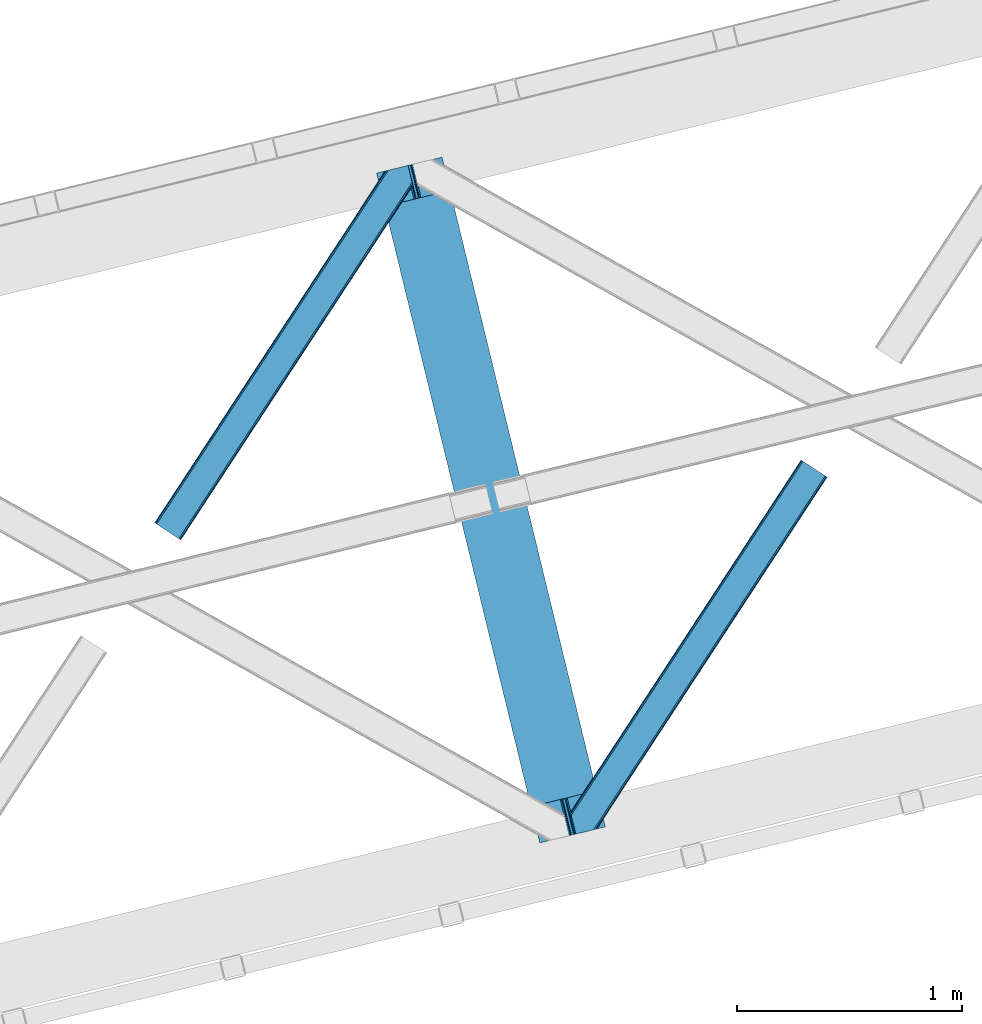
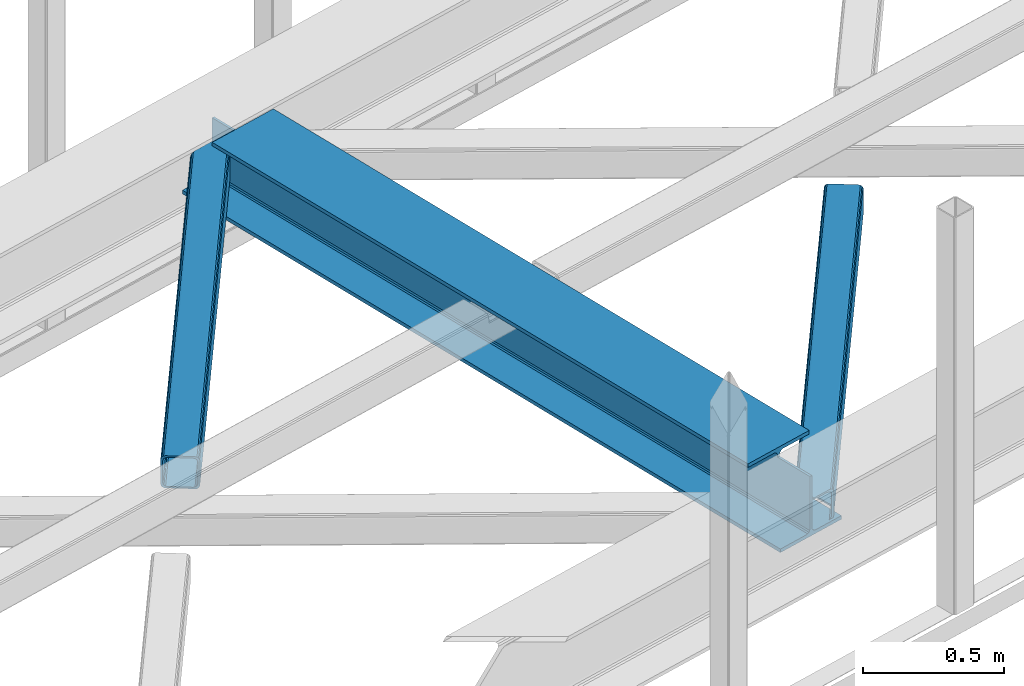
# One storey, part 27 of 67: 2 members, 1 beam.
"""IFC4 building model written with IfcOpenShell, lengths in millimetres."""

from ifc_helpers import new_model, entity, si_unit, converted_unit, derived_unit, direction, frame, origin, place, context, subcontext, project, spatial, triangles, polygons, material, type_object, element, save


model = new_model("IFC4")

# Units and contexts
model_context = context("Model", 3, precision=0.01, world=origin(), true_north=direction((6.12303176911189e-17, 1.0)))
plan_context = context("Plan", 3, precision=0.01, world=origin(), true_north=direction((6.12303176911189e-17, 1.0)))
body_context = subcontext(model_context, "Body", "Model", "MODEL_VIEW")
ifc_project = project(units=[si_unit("LENGTHUNIT", "METRE", prefix="MILLI"), si_unit("AREAUNIT", "SQUARE_METRE"), si_unit("VOLUMEUNIT", "CUBIC_METRE"), converted_unit("PLANEANGLEUNIT", "DEGREE", entity("IfcRatioMeasure", 0.0174532925199433), si_unit("PLANEANGLEUNIT", "RADIAN"), dimensions=[0, 0, 0, 0, 0, 0, 0]), si_unit("MASSUNIT", "GRAM", prefix="KILO"), derived_unit("MASSDENSITYUNIT", [(si_unit("MASSUNIT", "GRAM", prefix="KILO"), 1), (si_unit("LENGTHUNIT", "METRE"), -3)]), derived_unit("MOMENTOFINERTIAUNIT", [(si_unit("LENGTHUNIT", "METRE"), 4)]), si_unit("TIMEUNIT", "SECOND"), si_unit("FREQUENCYUNIT", "HERTZ"), si_unit("THERMODYNAMICTEMPERATUREUNIT", "DEGREE_CELSIUS"), derived_unit("THERMALTRANSMITTANCEUNIT", [(si_unit("MASSUNIT", "GRAM", prefix="KILO"), 1), (si_unit("THERMODYNAMICTEMPERATUREUNIT", "KELVIN"), -1), (si_unit("TIMEUNIT", "SECOND"), -3)]), derived_unit("VOLUMETRICFLOWRATEUNIT", [(si_unit("LENGTHUNIT", "METRE"), 3), (si_unit("TIMEUNIT", "SECOND"), -1)]), derived_unit("MASSFLOWRATEUNIT", [(si_unit("MASSUNIT", "GRAM", prefix="KILO"), 1), (si_unit("TIMEUNIT", "SECOND"), -1)]), derived_unit("ROTATIONALFREQUENCYUNIT", [(si_unit("TIMEUNIT", "SECOND"), -1)]), si_unit("ELECTRICCURRENTUNIT", "AMPERE"), si_unit("ELECTRICVOLTAGEUNIT", "VOLT"), si_unit("POWERUNIT", "WATT"), si_unit("FORCEUNIT", "NEWTON", prefix="KILO"), si_unit("ILLUMINANCEUNIT", "LUX"), si_unit("LUMINOUSFLUXUNIT", "LUMEN"), si_unit("LUMINOUSINTENSITYUNIT", "CANDELA"), derived_unit("USERDEFINED", [(si_unit("MASSUNIT", "GRAM", prefix="KILO"), -1), (si_unit("LENGTHUNIT", "METRE"), -2), (si_unit("TIMEUNIT", "SECOND"), 3), (si_unit("LUMINOUSFLUXUNIT", "LUMEN"), 1)]), derived_unit("LINEARVELOCITYUNIT", [(si_unit("LENGTHUNIT", "METRE"), 1), (si_unit("TIMEUNIT", "SECOND"), -1)]), si_unit("PRESSUREUNIT", "PASCAL"), derived_unit("USERDEFINED", [(si_unit("LENGTHUNIT", "METRE"), -2), (si_unit("MASSUNIT", "GRAM", prefix="KILO"), 1), (si_unit("TIMEUNIT", "SECOND"), -2)]), derived_unit("LINEARFORCEUNIT", [(si_unit("MASSUNIT", "GRAM", prefix="KILO"), 1), (si_unit("LENGTHUNIT", "METRE"), 1), (si_unit("TIMEUNIT", "SECOND"), -2), (si_unit("LENGTHUNIT", "METRE"), -1)]), derived_unit("PLANARFORCEUNIT", [(si_unit("MASSUNIT", "GRAM", prefix="KILO"), 1), (si_unit("LENGTHUNIT", "METRE"), 1), (si_unit("TIMEUNIT", "SECOND"), -2), (si_unit("LENGTHUNIT", "METRE"), -2)])], contexts=[model_context, plan_context])

# Site, building, storey
site_placement = place(None, origin())
site = spatial("IfcSite", under=ifc_project, at=site_placement, CompositionType="ELEMENT")
building_placement = place(site_placement, origin())
building = spatial("IfcBuilding", under=site, at=building_placement, CompositionType="ELEMENT")
storey_placement = place(building_placement, frame((0.0, 0.0, 19800.0)))
storey = spatial("IfcBuildingStorey", under=building, at=storey_placement, CompositionType="ELEMENT", Elevation=19800.0)

# Beam
ifc_material = material(Name="Metal painted (White)")
beam_type = type_object("IfcBeamType", PredefinedType="BEAM")
beam_placement = place(storey_placement, frame((-46287.0610062402, 6511.96838491939, 3807.02022389142)))
element("IfcBeam", 1, at=beam_placement, inside=storey, type_object=beam_type, material=ifc_material, ObjectType="Steel Beam", PredefinedType="BEAM", context=body_context, shape_type="Tessellation", body=[
    polygons([(1018.16648378329, 71.0478278971, 15.5000000000008), (1018.16648378329, 71.047827897101, 0.0), (291.465617442446, 3052.25531830421, 0.0), (291.465617442446, 3052.25531830421, 15.5000000000008), (894.779372399329, 40.970914087328, 15.5000000000008), (168.078506058474, 3022.17840449444, 15.5000000000008), (888.087028625375, 39.3395844888232, 16.8701684147984), (161.386162284528, 3020.54707489594, 16.8701684147984), (882.413533524759, 37.9566100336508, 20.7720779386434), (155.712667183904, 3019.16410044076, 20.7720779386434), (878.622625296184, 37.0325360459173, 26.6116982174294), (151.921758955329, 3018.24002645303, 26.6116982174294), (877.291435352779, 36.7080444135018, 33.500000000001), (150.590569011932, 3017.91553482061, 33.500000000001), (140.875048430522, 3015.54727389071, 33.500000000001), (140.875048430522, 3015.54727389071, 259.000000000002), (150.590569011932, 3017.91553482061, 259.000000000002), (8.66293703438714e-12, 2981.20749040711, 0.0), (8.66293703438714e-12, 2981.20749040711, 15.4999999999965), (123.387111383972, 3011.28440421689, 15.5000000000008), (130.079455157935, 3012.91573381539, 16.8701684147984), (135.752950258542, 3014.29870827056, 20.7720779386434), (139.543858487126, 3015.2227822583, 26.6116982174294), (877.291435352788, 36.7080444135029, 259.000000000002), (867.575914771378, 34.3397834835992, 259.000000000002), (867.575914771378, 34.3397834835992, 33.500000000001), (866.244724827981, 34.0152918511848, 26.6116982174294), (862.453816599397, 33.0912178634502, 20.7720779386434), (856.78032149879, 31.7082434082767, 16.8701684147984), (850.087977724828, 30.0769138097719, 15.5000000000008), (726.700866340864, 1.08286712929839e-12, 15.4999999999965), (726.700866340864, 1.08286712929839e-12, 0.0), (838.124523615921, 197.385937999178, 259.069791973884), (186.46972209998, 2870.72539801218, 259.000000000002), (186.69311520182, 2869.80895360721, 259.617303331124), (186.705504045446, 2869.75812937344, 266.500003008253), (837.979344808156, 197.981416001703, 266.500002998871), (837.979694928899, 197.979979696969, 260.000004007589), (828.499586345885, 194.64586594443, 259.006343171919), (828.27621632612, 195.562317481911, 259.617303331124), (828.263827482486, 195.613141715684, 266.500003008253), (176.989986719793, 2867.38985508742, 266.500002998871), (176.98963659904, 2867.39129139215, 260.000004007589), (176.844830940705, 2867.98534020594, 259.07612046749), (176.754201518561, 2868.35713708228, 259.000000000002), (839.310832678074, 198.304685446389, 273.388305639783), (843.10110926677, 199.231350618302, 279.227924098781), (848.774180214309, 200.616065081978, 283.129832400619), (855.466371895434, 202.248018612791, 284.500000377228), (978.853400583278, 232.325271667903, 284.500000138971), (978.851730776626, 232.332121736634, 299.999995328161), (687.386308679356, 161.283492472592, 299.999995890962), (687.387978486008, 161.276642403861, 284.500000701776), (810.775007173852, 191.353895458971, 284.500000463519), (817.467494069999, 192.984637925551, 283.129832461069), (823.141405718751, 194.365903570076, 279.227924137322), (826.932940505751, 195.287407219373, 273.388305663684), (175.658498849865, 2867.06658564273, 273.388305639783), (171.868222261161, 2866.13992047082, 279.227924098781), (166.195151313631, 2864.75520600714, 283.129832400619), (159.502959632506, 2863.12325247633, 284.500000377228), (36.1159309446533, 2833.04599942122, 284.500000138971), (36.1176007513137, 2833.03914935249, 299.999995328161), (327.583022848584, 2904.08777861653, 299.999995890962), (327.581353041932, 2904.09462868526, 284.500000701776), (204.19432435408, 2874.01737563015, 284.500000463519), (197.50183745795, 2872.38663316357, 283.129832461069), (191.827925809181, 2871.00536751905, 279.227924137322), (188.036391022189, 2870.08386386975, 273.388305663684)], [[[1, 2, 3, 4]], [[5, 1, 4, 6]], [[7, 5, 6, 8]], [[9, 7, 8, 10]], [[11, 9, 10, 12]], [[13, 11, 12, 14]], [[15, 16, 17, 14, 12, 10, 8, 6, 4, 3, 18, 19, 20, 21, 22, 23]], [[13, 24, 25, 26, 27, 28, 29, 30, 31, 32, 2, 1, 5, 7, 9, 11]], [[2, 32, 18, 3]], [[32, 31, 19, 18]], [[31, 30, 20, 19]], [[27, 26, 15, 23]], [[28, 27, 23, 22]], [[29, 28, 22, 21]], [[30, 29, 21, 20]], [[33, 24, 13, 14, 17, 34, 35, 36, 37, 38]], [[25, 39, 40, 41, 42, 43, 44, 16, 15, 26]], [[39, 25, 24, 33]], [[45, 34, 17, 16]], [[41, 40, 38, 37, 46, 47, 48, 49, 50, 51, 52, 53, 54, 55, 56, 57]], [[42, 58, 59, 60, 61, 62, 63, 64, 65, 66, 67, 68, 69, 36, 35, 43]], [[46, 37, 36, 69]], [[47, 46, 69, 68]], [[48, 47, 68, 67]], [[49, 48, 67, 66]], [[50, 49, 66, 65]], [[51, 50, 65, 64]], [[52, 51, 64, 63]], [[53, 52, 63, 62]], [[54, 53, 62, 61]], [[55, 54, 61, 60]], [[56, 55, 60, 59]], [[57, 56, 59, 58]], [[41, 57, 58, 42]]], closed=False),
])

# Members
member_type_1 = type_object("IfcMemberType", PredefinedType="BRACE")
member_1_placement = place(storey_placement, frame((-47275.2632080078, 7859.97314300537, 3823.99987792968)))
element("IfcMember", 2, at=member_1_placement, inside=storey, type_object=member_type_1, ObjectType="Steel Horizontal Brace", PredefinedType="BRACE", context=body_context, shape_type="Tessellation", body=[
    triangles([(994.771838378903, 1564.02662658691, 0.0), (1028.82092285156, 1424.34736175537, 0.0), (14.6409667968692, 67.104043579101, 0.0), (102.482116699219, 9.58604278564417, 0.0), (1.11156005859084, 75.9604797363281, 10.8039916992202), (0.0, 76.6900863647461, 17.5012573242202), (1025.02580566406, 1642.17883300781, 17.5012573242202), (4.28811035156104, 73.8821182250977, 5.12526855468968), (990.474426269531, 1585.87703704834, 9.49942016601563), (990.041894531249, 1584.44747314453, 8.74132690429906), (989.907019042963, 1583.99226837158, 8.49948120117188), (990.758129882808, 1580.48841247559, 5.12526855468968), (1027.30473632812, 1642.73519439697, 10.8691040039084), (1027.77912597656, 1642.8503036499, 9.49942016601563), (992.599877929686, 1572.93538513184, 1.33247680664135), (9.03665771483793, 70.7724243164057, 1.33247680664135), (1025.02580566406, 1642.17883300781, 122.499499511719), (0.0, 76.6900863647461, 122.499499511719), (1026.9187133789, 1642.64101409912, 129.196765136719), (1.11156005859084, 75.9604797363281, 129.196765136719), (1032.31373291015, 1643.95605010986, 134.87548828125), (4.28811035156104, 73.8821182250977, 134.87548828125), (1040.39230957031, 1645.92395324707, 138.668280029298), (9.03665771483793, 70.7724243164057, 138.668280029298), (1049.91730957031, 1648.24590454102, 140.00075683594), (14.6409667968692, 67.104043579101, 140.00075683594), (994.869506835938, 1567.85139312744, 9.49942016601563), (994.757885742183, 1567.00667724609, 9.2947814941399), (994.646264648436, 1566.15091552734, 9.08781738281323), (994.539294433591, 1565.306199646, 8.8831787109375), (994.743933105463, 1564.14464263916, 8.49948120117188), (1047.05236816406, 1647.54827270508, 9.49942016601563), (14.892114257811, 66.9377746582031, 8.3320495605476), (20.4964233398423, 63.2693939208984, 6.99957275390625), (997.041467285155, 1554.71498565674, 6.99957275390625), (10.1435668945269, 70.0474685668942, 12.1248413085959), (1042.27126464844, 1646.3826461792, 12.1248413085959), (1036.87624511719, 1645.06761016846, 17.8035644531265), (1034.98333740234, 1644.60601043701, 24.5008300781265), (6.96701660155668, 72.1258300781246, 17.8035644531265), (5.85545654296584, 72.8554367065426, 24.5008300781265), (1026.55129394531, 1433.65958404541, 6.99957275390625), (96.6266601562456, 13.4206924438477, 6.99957275390625), (1028.71395263672, 1424.77640533447, 8.41343994140698), (1032.83463134765, 1407.88615722656, 5.12526855468968), (1033.6857421875, 1404.38230133057, 8.49948120117188), (1030.99288330078, 1415.43918457031, 1.33247680664135), (1034.98333740234, 1644.60601043701, 115.499926757813), (5.85545654296584, 72.8554367065426, 115.499926757813), (1050.34519042968, 1648.35113067627, 131.668707275392), (1059.87019042968, 1650.67308197021, 133.001184082033), (20.4964233398423, 63.2693939208984, 133.001184082033), (14.892114257811, 66.9377746582031, 131.668707275392), (1042.27126464844, 1646.3826461792, 127.873590087893), (10.1435668945269, 70.0474685668942, 127.873590087893), (1036.87624511719, 1645.06761016846, 122.197192382813), (6.96701660155668, 72.1258300781246, 122.197192382813), (1128.10788574218, 1667.30578765869, 140.00075683594), (1128.10788574218, 1667.30578765869, 133.001184082033), (1144.32550048828, 1600.75810546875, 140.00075683594), (102.482116699219, 9.58604278564417, 140.00075683594), (1142.05587158203, 1610.06974639893, 133.001184082033), (96.6266601562456, 13.4206924438477, 133.001184082033), (1146.4974609375, 1591.84934692383, 138.668280029298), (108.08642578125, 5.91766204833948, 138.668280029298), (1148.33920898437, 1584.29631958008, 134.87548828125), (112.834973144527, 2.80738677978479, 134.87548828125), (1149.57169189453, 1579.2501159668, 129.196765136719), (116.011523437497, 0.729606628417969, 129.196765136719), (1150.00422363281, 1577.47813110352, 122.499499511719), (117.123083496088, 0.0, 122.499499511719), (1150.00422363281, 1577.47813110352, 17.5012573242202), (117.123083496088, 0.0, 17.5012573242202), (106.979516601561, 6.64203643798828, 127.873590087893), (110.151416015622, 4.56425628662055, 122.197192382813), (111.267626953122, 3.83464965820258, 115.499926757813), (102.230969238277, 9.75231170654297, 131.668707275392), (116.011523437497, 0.729606628417969, 10.8039916992202), (106.979516601561, 6.64203643798828, 12.1248413085959), (112.834973144527, 2.80738677978479, 5.12526855468968), (111.267626953122, 3.83464965820258, 24.5008300781265), (110.151416015622, 4.56425628662055, 17.8035644531265), (108.08642578125, 5.91766204833948, 1.33247680664135), (102.230969238277, 9.75231170654297, 8.3320495605476), (1147.30206298828, 1588.56233825684, 122.197192382813), (1147.73459472656, 1586.78977203369, 115.499926757813), (1146.06958007813, 1593.60854187012, 127.873590087893), (1144.22783203125, 1601.160987854, 131.668707275392), (1147.73459472656, 1586.78977203369, 24.5008300781265), (1147.21369628906, 1588.9239440918, 17.8686767578147), (1149.994921875, 1577.51591949463, 16.5013183593765), (1147.10672607421, 1589.36519622803, 16.5013183593765), (1145.27427978515, 1573.10804901123, 10.8714294433594), (1034.61591796875, 1404.78809051514, 9.49942016601563), (1144.12551269531, 1572.03427734375, 9.49942016601563), (1142.79071044922, 1588.5978012085, 12.1248413085959), (1030.22548828125, 1422.8143157959, 9.49942016601563), (1029.19764404296, 1423.6724029541, 8.80643920898365), (1139.7304321289, 1590.05992126465, 9.49942016601563)], [[1, 2, 3], [4, 3, 2], [5, 6, 7], [8, 9, 10], [11, 12, 8], [5, 13, 9], [9, 8, 5], [13, 14, 9], [15, 1, 16], [3, 16, 1], [12, 15, 8], [16, 8, 15], [7, 13, 5], [17, 7, 18], [6, 18, 7], [19, 17, 20], [18, 20, 17], [21, 19, 22], [20, 22, 19], [23, 21, 24], [22, 24, 21], [25, 23, 26], [24, 26, 23], [27, 28, 9], [28, 29, 10], [29, 30, 10], [30, 31, 11], [14, 32, 27], [27, 9, 14], [33, 34, 35], [36, 33, 31], [31, 30, 36], [28, 36, 29], [28, 27, 36], [36, 30, 29], [32, 37, 27], [36, 27, 37], [35, 31, 33], [38, 39, 40], [41, 40, 39], [37, 38, 36], [40, 36, 38], [42, 35, 34], [34, 43, 42], [1, 35, 42], [31, 12, 11], [1, 31, 35], [31, 15, 12], [31, 1, 15], [2, 1, 42], [44, 2, 42], [45, 44, 46], [44, 47, 2], [44, 45, 47], [39, 48, 49], [49, 41, 39], [50, 51, 52], [52, 53, 50], [54, 50, 53], [53, 55, 54], [56, 54, 55], [55, 57, 56], [48, 56, 57], [57, 49, 48], [56, 17, 19], [50, 23, 25], [58, 51, 25], [51, 58, 59], [51, 50, 25], [54, 23, 50], [54, 56, 21], [21, 23, 54], [19, 21, 56], [39, 7, 17], [37, 14, 38], [56, 48, 17], [37, 32, 14], [39, 38, 7], [48, 39, 17], [13, 7, 38], [38, 14, 13], [60, 25, 61], [25, 60, 58], [26, 61, 25], [51, 62, 63], [51, 59, 62], [63, 52, 51], [64, 60, 61], [61, 65, 64], [66, 64, 65], [65, 67, 66], [68, 66, 67], [67, 69, 68], [70, 68, 69], [69, 71, 70], [72, 70, 71], [71, 73, 72], [69, 74, 75], [76, 73, 71], [69, 75, 71], [69, 67, 74], [75, 76, 71], [74, 67, 65], [63, 61, 26], [61, 77, 65], [77, 61, 63], [77, 74, 65], [78, 79, 80], [81, 73, 76], [73, 82, 78], [82, 73, 81], [78, 82, 79], [4, 43, 3], [83, 80, 79], [79, 84, 83], [84, 43, 4], [4, 83, 84], [55, 24, 22], [26, 52, 63], [26, 53, 52], [53, 26, 24], [55, 53, 24], [49, 18, 6], [20, 57, 55], [22, 20, 55], [57, 20, 18], [49, 57, 18], [16, 36, 8], [3, 43, 34], [34, 33, 3], [33, 36, 16], [16, 3, 33], [5, 8, 36], [6, 41, 49], [40, 6, 5], [6, 40, 41], [40, 5, 36], [85, 86, 75], [76, 75, 86], [87, 85, 74], [75, 74, 85], [88, 87, 77], [74, 77, 87], [62, 88, 63], [77, 63, 88], [86, 89, 76], [81, 76, 89], [90, 91, 92], [70, 72, 89], [72, 90, 89], [89, 86, 70], [72, 91, 90], [85, 70, 86], [68, 70, 85], [66, 85, 87], [85, 66, 68], [87, 64, 66], [88, 64, 87], [88, 62, 60], [88, 60, 64], [62, 58, 60], [62, 59, 58], [73, 78, 93], [93, 72, 73], [94, 93, 78], [94, 95, 93], [80, 45, 46], [46, 78, 80], [46, 94, 78], [47, 45, 83], [80, 83, 45], [2, 47, 4], [83, 4, 47], [93, 91, 72], [82, 81, 89], [82, 92, 96], [82, 90, 92], [84, 97, 98], [79, 96, 97], [97, 84, 79], [96, 99, 97], [43, 84, 44], [44, 42, 43], [96, 79, 82], [89, 90, 82], [96, 91, 93], [96, 92, 91], [96, 95, 99], [93, 95, 96], [99, 95, 97], [94, 97, 95]]),
])
member_type_2 = type_object("IfcMemberType", PredefinedType="BRACE")
member_2_placement = place(storey_placement, frame((-45423.9436523438, 6551.04489898682, 3823.99987792968)))
element("IfcMember", 3, at=member_2_placement, inside=storey, type_object=member_type_2, ObjectType="Steel Horizontal Brace", PredefinedType="BRACE", context=body_context, shape_type="Tessellation", body=[
    triangles([(109.770043945318, 259.949830627442, 7.52047119140843), (115.030187988283, 238.365682983399, 7.77626953125218), (114.216284179689, 239.946981811524, 8.3320495605476), (108.811962890628, 259.662057495118, 8.52041015625218), (113.634924316408, 239.859196472168, 8.52041015625218), (112.20710449219, 237.677352905273, 8.52041015625218), (91.0363037109419, 232.516621398926, 8.52041015625218), (109.537500000006, 237.026229858398, 9.49942016601563), (90.2642578125015, 232.328260803223, 9.49942016601563), (5.02294921875, 77.405158996582, 9.49942016601563), (0.62786865234375, 95.4308029174808, 9.49942016601563), (1046.62448730469, 1651.75324859619, 6.99957275390625), (1041.02017822266, 1655.4216293335, 8.3320495605476), (116.699853515631, 231.514938354492, 6.99957275390625), (1036.27163085938, 1658.53190460205, 12.1248413085959), (3.92999267578125, 81.8752349853521, 12.1248413085959), (1033.09973144531, 1660.61026611328, 17.8035644531265), (2.70216064453416, 86.9220199584961, 17.8035644531265), (1031.98352050781, 1661.3398727417, 24.5008300781265), (2.26962890625146, 88.6940048217775, 24.5008300781265), (1122.7547241211, 1601.90454711914, 6.99957275390625), (146.209680175787, 110.459536743164, 6.99957275390625), (1031.98352050781, 1661.3398727417, 115.499926757813), (2.26962890625146, 88.6940048217775, 115.499926757813), (1033.09973144531, 1660.61026611328, 122.197192382813), (2.70216064453416, 86.9220199584961, 122.197192382813), (1036.27163085938, 1658.53190460205, 127.873590087893), (3.92999267578125, 81.8752349853521, 127.873590087893), (1041.02017822266, 1655.4216293335, 131.668707275392), (5.77174072265916, 74.322789001465, 131.668707275392), (1046.62448730469, 1651.75324859619, 133.001184082033), (7.94370117187646, 65.4140304565435, 133.001184082033), (1027.24427490235, 1664.44433441162, 10.8039916992202), (0.520898437505821, 95.8714736938482, 10.8691040039084), (0.0, 98.0056457519531, 17.5012573242202), (1035.16472167969, 1659.2562789917, 1.33247680664135), (112.258264160162, 249.73533782959, 1.33247680664135), (110.546740722661, 256.772117614746, 5.59500732422021), (109.077062988283, 259.839372253418, 8.32042236328198), (1030.41617431641, 1662.36655426025, 5.12526855468968), (1040.76903076172, 1655.58789825439, 0.0), (114.430224609379, 240.826579284668, 0.0), (1026.12806396485, 1665.1745223999, 17.5012573242202), (1128.61018066407, 1598.06989746094, 0.0), (148.479309082031, 101.147314453126, 0.0), (150.651269531256, 92.2385559082031, 1.33247680664135), (148.507214355472, 101.029298400879, 8.49948120117188), (152.493017578126, 84.686109924317, 5.12526855468968), (153.348779296881, 81.1822540283201, 8.49948120117188), (1026.12806396485, 1665.1745223999, 122.499499511719), (0.0, 98.0056457519531, 122.499499511719), (1040.76903076172, 1655.58789825439, 140.00075683594), (1035.16472167969, 1659.2562789917, 138.668280029298), (3.50211181640771, 83.6350112915043, 138.668280029298), (5.674072265625, 74.7256713867191, 140.00075683594), (1030.41617431641, 1662.36655426025, 134.87548828125), (1.66036376953707, 91.1874572753904, 134.87548828125), (1027.24427490235, 1664.44433441162, 129.196765136719), (0.432531738282705, 96.2336608886717, 129.196765136719), (23.8915649414121, 0.0, 140.00075683594), (23.8915649414121, 0.0, 133.001184082033), (1128.61018066407, 1598.06989746094, 140.00075683594), (93.3338378906265, 16.9280364990236, 140.00075683594), (1122.7547241211, 1601.90454711914, 133.001184082033), (83.3809570312515, 14.501440429688, 133.001184082033), (1143.25579833984, 1588.48385467529, 122.499499511719), (1142.13958740234, 1589.21346130371, 129.196765136719), (118.225341796875, 22.9951080322271, 122.499499511719), (116.332434082033, 22.5335083007813, 129.196765136719), (1138.96303710938, 1591.29124145508, 134.87548828125), (110.937414550783, 21.2178909301756, 134.87548828125), (1134.2144897461, 1594.40151672363, 138.668280029298), (102.858837890628, 19.2499877929686, 138.668280029298), (1143.25579833984, 1588.48385467529, 17.5012573242202), (118.225341796875, 22.9951080322271, 17.5012573242202), (1142.13958740234, 1589.21346130371, 10.8039916992202), (1133.10758056641, 1595.12647247314, 12.1248413085959), (1136.28413085938, 1593.04811096191, 17.8035644531265), (1137.39569091797, 1592.3185043335, 24.5008300781265), (1138.96303710938, 1591.29124145508, 5.12526855468968), (1134.2144897461, 1594.40151672363, 1.33247680664135), (1128.35903320313, 1598.23616638184, 8.3320495605476), (1133.10758056641, 1595.12647247314, 127.873590087893), (1137.39569091797, 1592.3185043335, 115.499926757813), (1136.28413085938, 1593.04811096191, 122.197192382813), (1128.35903320313, 1598.23616638184, 131.668707275392), (92.9059570312529, 16.8228103637693, 131.668707275392), (100.979882812506, 18.79129486084, 127.873590087893), (106.374902343756, 20.106330871582, 122.197192382813), (108.267810058598, 20.5685119628906, 115.499926757813), (108.267810058598, 20.5685119628906, 24.5008300781265), (100.979882812506, 18.79129486084, 12.1248413085959), (115.472021484376, 22.32421875, 9.49942016601563), (106.374902343756, 20.106330871582, 17.8035644531265), (96.1987792968794, 17.6262496948248, 9.49942016601563), (115.946411132813, 22.4393280029299, 10.8691040039084), (153.060424804688, 80.2392883300781, 8.99945068359375), (152.776721191411, 79.2969039916998, 9.49942016601563), (148.711853027344, 99.8677413940432, 8.8831787109375), (148.604882812506, 99.023606872559, 9.08781738281323), (148.493261718751, 98.1672637939455, 9.2947814941399), (148.381640625004, 97.3225479125977, 9.49942016601563)], [[1, 2, 3], [4, 5, 6], [6, 7, 4], [7, 6, 8], [8, 9, 7], [9, 8, 10], [10, 11, 9], [12, 13, 3], [3, 2, 12], [2, 14, 12], [15, 16, 8], [8, 13, 15], [8, 5, 13], [16, 10, 8], [8, 6, 5], [15, 17, 18], [18, 16, 15], [17, 19, 20], [20, 18, 17], [21, 12, 14], [14, 22, 21], [19, 23, 20], [24, 20, 23], [23, 25, 24], [26, 24, 25], [25, 27, 26], [28, 26, 27], [27, 29, 28], [30, 28, 29], [29, 31, 30], [32, 30, 31], [33, 34, 35], [36, 37, 38], [33, 4, 9], [33, 1, 39], [9, 34, 33], [9, 11, 34], [4, 7, 9], [40, 38, 1], [1, 33, 40], [38, 40, 36], [36, 41, 37], [42, 37, 41], [35, 43, 33], [41, 44, 42], [45, 42, 44], [14, 42, 22], [37, 2, 38], [2, 37, 42], [38, 2, 1], [42, 14, 2], [22, 42, 45], [46, 47, 45], [47, 46, 48], [45, 47, 22], [48, 49, 47], [50, 43, 35], [35, 51, 50], [52, 53, 54], [54, 55, 52], [53, 56, 57], [57, 54, 53], [56, 58, 59], [59, 57, 56], [58, 50, 51], [51, 59, 58], [28, 57, 26], [30, 32, 55], [32, 60, 55], [32, 61, 60], [54, 30, 55], [28, 54, 57], [16, 11, 10], [28, 30, 54], [51, 35, 20], [24, 26, 51], [24, 51, 20], [57, 59, 26], [26, 59, 51], [35, 18, 20], [18, 11, 16], [11, 18, 34], [35, 34, 18], [62, 55, 63], [62, 52, 55], [55, 60, 63], [64, 32, 31], [32, 64, 65], [61, 32, 65], [66, 67, 68], [69, 68, 67], [67, 70, 69], [71, 69, 70], [70, 72, 71], [73, 71, 72], [72, 62, 73], [63, 73, 62], [74, 66, 75], [68, 75, 66], [76, 77, 78], [79, 66, 74], [76, 78, 74], [76, 80, 77], [78, 79, 74], [77, 80, 81], [21, 44, 41], [44, 82, 81], [82, 44, 21], [82, 77, 81], [67, 83, 70], [84, 66, 79], [66, 85, 67], [85, 66, 84], [67, 85, 83], [62, 64, 52], [72, 70, 83], [83, 86, 72], [86, 64, 62], [62, 72, 86], [15, 36, 40], [41, 12, 21], [41, 13, 12], [13, 41, 36], [15, 13, 36], [19, 43, 50], [33, 17, 15], [40, 33, 15], [17, 33, 43], [19, 17, 43], [53, 27, 56], [52, 64, 31], [31, 29, 52], [29, 27, 53], [53, 52, 29], [58, 56, 27], [50, 23, 19], [25, 50, 58], [50, 25, 23], [25, 58, 27], [64, 86, 87], [87, 65, 64], [86, 83, 88], [88, 87, 86], [83, 85, 89], [89, 88, 83], [85, 84, 90], [90, 89, 85], [84, 79, 91], [91, 90, 84], [89, 68, 69], [87, 73, 63], [60, 65, 63], [65, 60, 61], [65, 87, 63], [88, 73, 87], [88, 89, 71], [71, 73, 88], [69, 71, 89], [91, 75, 68], [92, 93, 94], [89, 90, 68], [92, 95, 93], [91, 94, 75], [90, 91, 68], [96, 75, 94], [94, 93, 96], [76, 74, 75], [49, 80, 97], [98, 97, 80], [49, 48, 80], [76, 96, 98], [98, 80, 76], [96, 93, 98], [44, 81, 45], [46, 45, 81], [81, 80, 46], [48, 46, 80], [75, 96, 76], [82, 21, 22], [77, 82, 47], [47, 99, 77], [77, 100, 101], [100, 77, 99], [101, 102, 77], [77, 102, 92], [95, 92, 102], [22, 47, 82], [79, 78, 91], [94, 91, 78], [78, 77, 94], [92, 94, 77], [102, 101, 98], [101, 100, 97], [100, 99, 49], [99, 47, 49], [102, 98, 93], [93, 95, 102]]),
])

save(model, "model.ifc")
